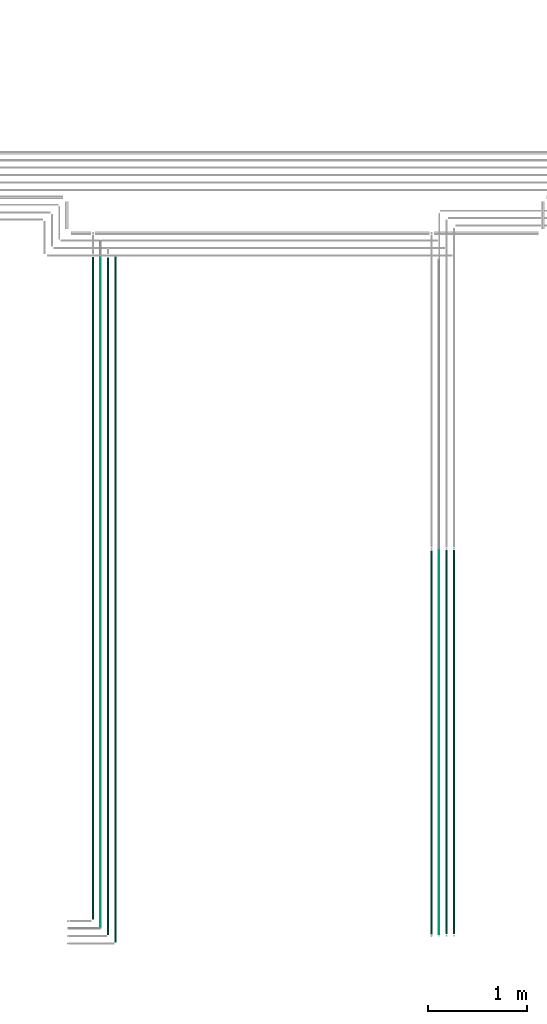
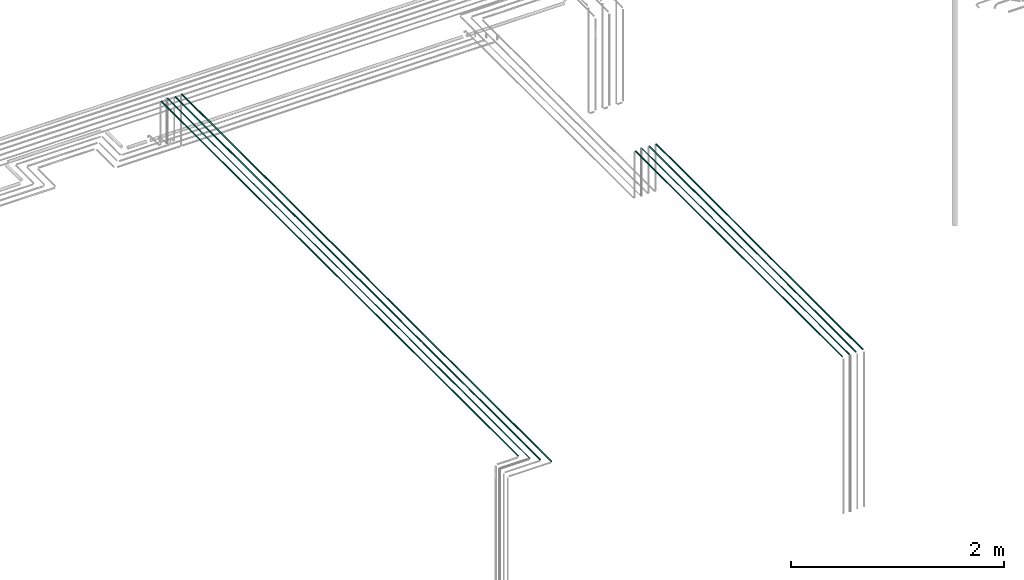
# One storey, part 13 of 65: 8 flow segments.
"""IFC2X3 building model written with IfcOpenShell, lengths in millimetres."""

from ifc_helpers import new_model, entity, si_unit, converted_unit, derived_unit, direction, frame, frame_2d, origin, origin_2d_with_axis, place, context, subcontext, project, spatial, circle, extrude, type_object, element, save


model = new_model("IFC2X3")

# Units and contexts
model_context = context("Model", 3, precision=0.01, world=origin(), true_north=direction((6.12303176911189e-17, 1.0)))
body_context = subcontext(model_context, "Body", "Model", "MODEL_VIEW")
ifc_project = project(units=[si_unit("LENGTHUNIT", "METRE", prefix="MILLI"), si_unit("AREAUNIT", "SQUARE_METRE"), si_unit("VOLUMEUNIT", "CUBIC_METRE"), converted_unit("PLANEANGLEUNIT", "DEGREE", entity("IfcRatioMeasure", 0.0174532925199433), si_unit("PLANEANGLEUNIT", "RADIAN"), dimensions=[0, 0, 0, 0, 0, 0, 0]), si_unit("MASSUNIT", "GRAM", prefix="KILO"), derived_unit("MASSDENSITYUNIT", [(si_unit("MASSUNIT", "GRAM", prefix="KILO"), 1), (si_unit("LENGTHUNIT", "METRE"), -3)]), derived_unit("MOMENTOFINERTIAUNIT", [(si_unit("LENGTHUNIT", "METRE"), 4)]), si_unit("TIMEUNIT", "SECOND"), si_unit("FREQUENCYUNIT", "HERTZ"), si_unit("THERMODYNAMICTEMPERATUREUNIT", "DEGREE_CELSIUS"), derived_unit("THERMALTRANSMITTANCEUNIT", [(si_unit("MASSUNIT", "GRAM", prefix="KILO"), 1), (si_unit("THERMODYNAMICTEMPERATUREUNIT", "KELVIN"), -1), (si_unit("TIMEUNIT", "SECOND"), -3)]), derived_unit("VOLUMETRICFLOWRATEUNIT", [(si_unit("LENGTHUNIT", "METRE"), 3), (si_unit("TIMEUNIT", "SECOND"), -1)]), derived_unit("MASSFLOWRATEUNIT", [(si_unit("MASSUNIT", "GRAM", prefix="KILO"), 1), (si_unit("TIMEUNIT", "SECOND"), -1)]), derived_unit("ROTATIONALFREQUENCYUNIT", [(si_unit("TIMEUNIT", "SECOND"), -1)]), si_unit("ELECTRICCURRENTUNIT", "AMPERE"), si_unit("ELECTRICVOLTAGEUNIT", "VOLT"), si_unit("POWERUNIT", "WATT"), si_unit("FORCEUNIT", "NEWTON", prefix="KILO"), si_unit("ILLUMINANCEUNIT", "LUX"), si_unit("LUMINOUSFLUXUNIT", "LUMEN"), si_unit("LUMINOUSINTENSITYUNIT", "CANDELA"), derived_unit("USERDEFINED", [(si_unit("MASSUNIT", "GRAM", prefix="KILO"), -1), (si_unit("LENGTHUNIT", "METRE"), -2), (si_unit("TIMEUNIT", "SECOND"), 3), (si_unit("LUMINOUSFLUXUNIT", "LUMEN"), 1)]), derived_unit("LINEARVELOCITYUNIT", [(si_unit("LENGTHUNIT", "METRE"), 1), (si_unit("TIMEUNIT", "SECOND"), -1)]), si_unit("PRESSUREUNIT", "PASCAL"), derived_unit("USERDEFINED", [(si_unit("LENGTHUNIT", "METRE"), -2), (si_unit("MASSUNIT", "GRAM", prefix="KILO"), 1), (si_unit("TIMEUNIT", "SECOND"), -2)]), derived_unit("LINEARFORCEUNIT", [(si_unit("MASSUNIT", "GRAM", prefix="KILO"), 1), (si_unit("LENGTHUNIT", "METRE"), 1), (si_unit("TIMEUNIT", "SECOND"), -2), (si_unit("LENGTHUNIT", "METRE"), -1)]), derived_unit("PLANARFORCEUNIT", [(si_unit("MASSUNIT", "GRAM", prefix="KILO"), 1), (si_unit("LENGTHUNIT", "METRE"), 1), (si_unit("TIMEUNIT", "SECOND"), -2), (si_unit("LENGTHUNIT", "METRE"), -2)])], contexts=[model_context])

# Site, building, storey
site_placement = place(None, frame((0.0, -0.00077364408347762, 0.0)))
site = spatial("IfcSite", under=ifc_project, at=site_placement, CompositionType="ELEMENT")
building_placement = place(site_placement, origin())
building = spatial("IfcBuilding", under=site, at=building_placement, CompositionType="ELEMENT")
storey_placement = place(building_placement, frame((0.0, 0.0, 19800.0)))
storey = spatial("IfcBuildingStorey", under=building, at=storey_placement, CompositionType="ELEMENT", Elevation=19800.0)

# Flow segments
pipe_segment_type = type_object("IfcPipeSegmentType", PredefinedType="NOTDEFINED")
flow_segment_1_placement = place(storey_placement, frame((59975.3052438068, 807.0, 3174.40472776419)))
element("IfcFlowSegment", 1, at=flow_segment_1_placement, inside=storey, type_object=pipe_segment_type, context=body_context, shape_type="SweptSolid", body=[
    extrude(circle(Radius=4.0, at=origin_2d_with_axis()), frame((5.59527223591499, 0.0, 5.59527223591499), z_axis=(0.0, 1.0, 0.0), x_axis=(-1.0, 0.0, 0.0)), (0.0, 0.0, 1.0), 3883.00000000001),
])
for number, where in (
    (2, (60048.3052438068, 813.0, 3172.40472776425)),
    (3, (60123.3052438068, 813.0, 3172.40472776415)),
):
    element("IfcFlowSegment", number, at=place(storey_placement, frame(where)), inside=storey, type_object=pipe_segment_type, context=body_context, shape_type="SweptSolid", body=[
        extrude(circle(Radius=6.0, at=origin_2d_with_axis()), frame((7.59527223591454, 0.0, 7.59527223591454), z_axis=(0.0, 1.0, 0.0), x_axis=(-1.0, 0.0, 0.0)), (0.0, 0.0, 1.0), 3873.00000000001),
    ])
flow_segment_2_placement = place(storey_placement, frame((59896.8052438068, 808.0, 3170.90472776373)))
element("IfcFlowSegment", 4, at=flow_segment_2_placement, inside=storey, type_object=pipe_segment_type, context=body_context, shape_type="SweptSolid", body=[
    extrude(circle(Radius=7.5, at=origin_2d_with_axis()), frame((9.09527223591419, 0.0, 9.09527223591419), z_axis=(0.0, 1.0, 0.0), x_axis=(1.0, 0.0, 0.0)), (0.0, 0.0, 1.0), 3874.00000000001),
])
flow_segment_3_placement = place(storey_placement, frame((56703.5132626869, 727.594329635764, 3142.40472776409)))
element("IfcFlowSegment", 5, at=flow_segment_3_placement, inside=storey, type_object=pipe_segment_type, context=body_context, shape_type="SweptSolid", body=[
    extrude(circle(Radius=6.0, at=origin_2d_with_axis()), frame((7.59527223591454, 0.0, 7.59527223591454), z_axis=(0.0, 1.0, 0.0), x_axis=(-1.0, 0.0, 0.0)), (0.0, 0.0, 1.0), 6923.40567036423),
])
flow_segment_4_placement = place(storey_placement, frame((56555.5132626869, 873.594329635765, 3144.40472776407)))
element("IfcFlowSegment", 6, at=flow_segment_4_placement, inside=storey, type_object=pipe_segment_type, context=body_context, shape_type="SweptSolid", body=[
    extrude(circle(Radius=4.0, at=origin_2d_with_axis()), frame((5.59527223591499, 0.0, 5.59527223591499), z_axis=(0.0, 1.0, 0.0), x_axis=(-1.0, 0.0, 0.0)), (0.0, 0.0, 1.0), 6781.40567036423),
])
flow_segment_5_placement = place(storey_placement, frame((56628.5132626869, 802.594329635763, 3142.40472776409)))
element("IfcFlowSegment", 7, at=flow_segment_5_placement, inside=storey, type_object=pipe_segment_type, context=body_context, shape_type="SweptSolid", body=[
    extrude(circle(Radius=6.0, at=origin_2d_with_axis()), frame((7.59527223591454, 0.0, 7.59527223591454), z_axis=(0.0, 1.0, 0.0), x_axis=(-1.0, 0.0, 0.0)), (0.0, 0.0, 1.0), 6839.40567036423),
])
flow_segment_6_placement = place(storey_placement, frame((56477.0132626869, 956.594329635764, 3140.90472776409)))
element("IfcFlowSegment", 8, at=flow_segment_6_placement, inside=storey, type_object=pipe_segment_type, context=body_context, shape_type="SweptSolid", body=[
    extrude(circle(Radius=7.5, at=frame_2d((-8.66293703438714e-12, 0.0), x_axis=(1.0, 0.0))), frame((9.09527223592286, 0.0, 9.09527223591419), z_axis=(0.0, 1.0, 0.0), x_axis=(1.0, 0.0, 0.0)), (0.0, 0.0, 1.0), 6690.40567036425),
])

save(model, "model.ifc")
